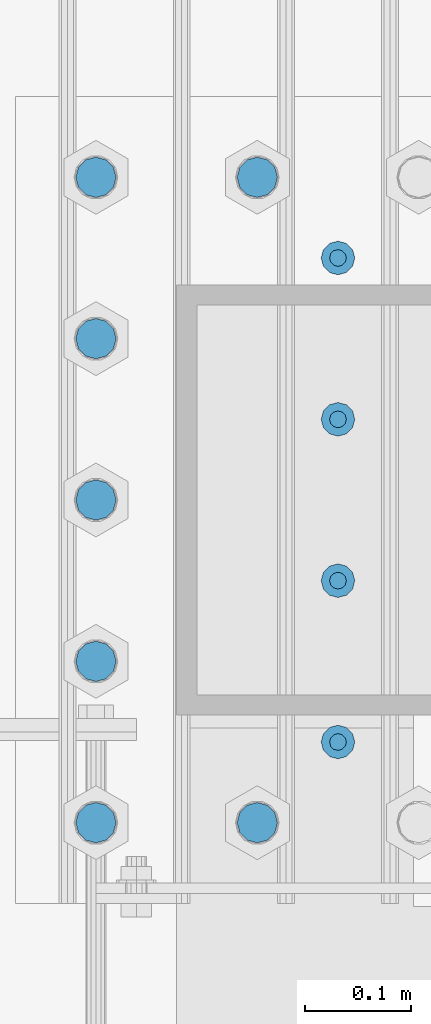
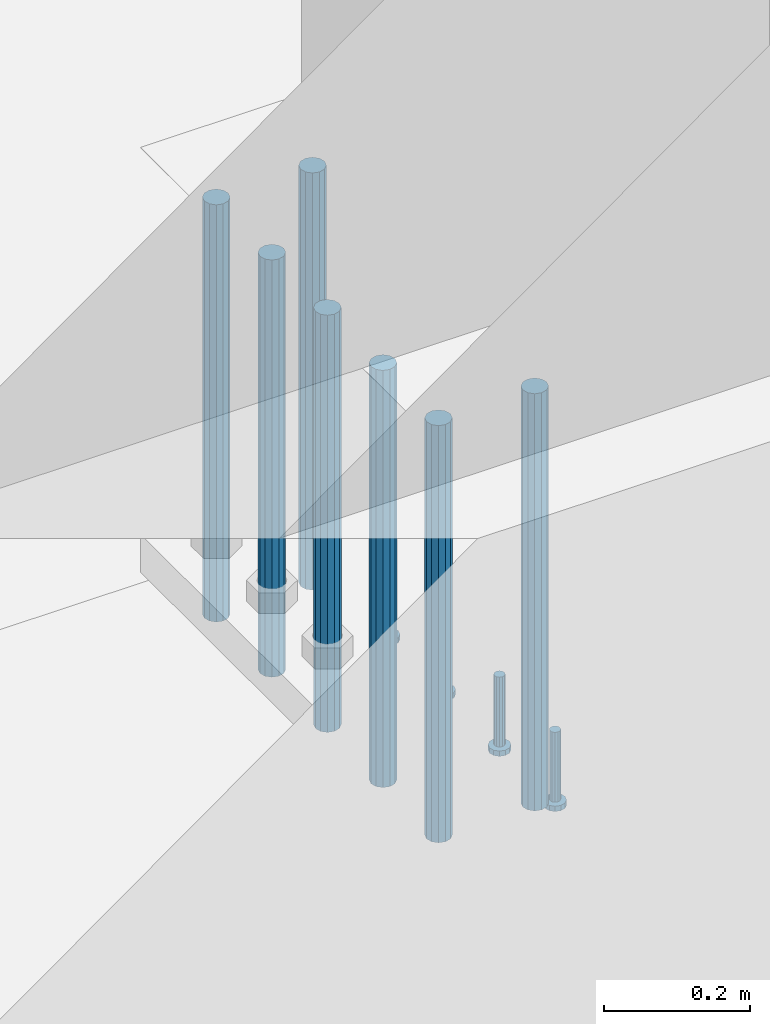
# One storey, part 1088 of 1876: 11 beams, 1 element without a shape of its own.
"""IFC2X3 building model written with IfcOpenShell, lengths in millimetres."""

from ifc_helpers import new_model, si_unit, frame, origin_with_axes, place, context, subcontext, project, spatial, faceted_brep, material, type_object, element, aggregate, save


model = new_model("IFC2X3")

# Units and contexts
model_context = context("Model", 3, precision=1e-05, world=origin_with_axes())
body_context = subcontext(model_context, "Body", "Model", "MODEL_VIEW")
ifc_project = project(units=[si_unit("LENGTHUNIT", "METRE", prefix="MILLI"), si_unit("AREAUNIT", "SQUARE_METRE"), si_unit("VOLUMEUNIT", "CUBIC_METRE"), si_unit("MASSUNIT", "GRAM", prefix="KILO"), si_unit("TIMEUNIT", "SECOND"), si_unit("PLANEANGLEUNIT", "RADIAN"), si_unit("SOLIDANGLEUNIT", "STERADIAN"), si_unit("THERMODYNAMICTEMPERATUREUNIT", "DEGREE_CELSIUS"), si_unit("LUMINOUSINTENSITYUNIT", "LUMEN")], contexts=[model_context])

# Site, building, storey
site_placement = place(None, origin_with_axes())
site = spatial("IfcSite", under=ifc_project, at=site_placement, CompositionType="ELEMENT")
building_placement = place(site_placement, origin_with_axes())
building = spatial("IfcBuilding", under=site, at=building_placement, Name="Undefined", CompositionType="ELEMENT")
storey_placement = place(building_placement, origin_with_axes())
storey = spatial("IfcBuildingStorey", under=building, at=storey_placement, Name="Undefined", CompositionType="ELEMENT", Elevation=0.0)

# Assembly, beams
assembly_placement = place(storey_placement, origin_with_axes())
assembly = element("IfcElementAssembly", 1, at=assembly_placement, inside=storey, Name="PLATE", AssemblyPlace="NOTDEFINED", PredefinedType="RIGID_FRAME")
ifc_material_1 = material(Name="STEEL/F1554-55, S1")
beam_type_1 = type_object("IfcBeamType", PredefinedType="NOTDEFINED")
beam_1_placement = place(assembly_placement, frame((7318.37500610347, -25552.4000091553, -63.4999999999993), z_axis=(-1.0, 0.0, 0.0), x_axis=(0.0, 0.0, -1.0)))
beam_1 = element("IfcBeam", 2, at=beam_1_placement, type_object=beam_type_1, material=ifc_material_1, Name="WELDED ANCHORS", context=body_context, shape_type="Brep", body=[
    faceted_brep([(0.0, -19.0500000000002, 0.0), (0.0, -16.4977839420935, -9.52500000000146), (698.499999999999, -16.4977839420935, -9.52499999999964), (698.499999999999, -19.0499999999993, 0.0), (0.0, -9.52500000000009, -16.4977839420935), (698.499999999999, -9.52500000000146, -16.4977839420935), (0.0, 0.0, -19.05), (698.499999999999, 0.0, -19.0500000000002), (0.0, 9.52500000000009, -16.4977839420935), (698.499999999999, 9.52500000000146, -16.4977839420935), (0.0, 16.4977839420935, -9.52500000000146), (698.499999999999, 16.4977839420935, -9.52499999999964), (-9.09494701772928e-13, 19.05, -1.81898940354586e-12), (698.499999999999, 19.0499999999993, 0.0), (0.0, 16.4977839420935, 9.52500000000146), (698.499999999999, 16.4977839420935, 9.52499999999964), (0.0, 9.52500000000009, 16.4977839420935), (698.499999999999, 9.52500000000146, 16.4977839420935), (0.0, 0.0, 19.0499999999993), (698.499999999999, 0.0, 19.0500000000002), (0.0, -9.52500000000009, 16.4977839420935), (698.499999999999, -9.52500000000146, 16.4977839420935), (0.0, -16.4977839420935, 9.52500000000146), (698.499999999999, -16.4977839420935, 9.52499999999964)], [[[0, 1, 2, 3]], [[1, 4, 5, 2]], [[4, 6, 7, 5]], [[6, 8, 9, 7]], [[8, 10, 11, 9]], [[10, 12, 13, 11]], [[12, 14, 15, 13]], [[14, 16, 17, 15]], [[16, 18, 19, 17]], [[18, 20, 21, 19]], [[20, 22, 23, 21]], [[22, 0, 3, 23]], [[5, 7, 9, 11, 13, 15, 17, 19, 21, 23, 3, 2]], [[22, 20, 18, 16, 14, 12, 10, 8, 6, 4, 1, 0]]]),
])
beam_2_placement = place(assembly_placement, frame((7318.37502441406, -25399.999987793, -63.4999999999993), z_axis=(-1.0, 0.0, 0.0), x_axis=(0.0, 0.0, -1.0)))
beam_2 = element("IfcBeam", 3, at=beam_2_placement, type_object=beam_type_1, material=ifc_material_1, Name="WELDED ANCHORS", context=body_context, shape_type="Brep", body=[
    faceted_brep([(0.0, -19.0500000000002, 0.0), (0.0, -16.4977839420935, -9.52500000000146), (698.499999999999, -16.4977839420935, -9.52499999999964), (698.499999999999, -19.0499999999993, 0.0), (0.0, -9.52500000000009, -16.4977839420935), (698.499999999999, -9.52500000000146, -16.4977839420935), (0.0, 0.0, -19.05), (698.499999999999, 0.0, -19.0500000000002), (0.0, 9.52500000000009, -16.4977839420935), (698.499999999999, 9.52500000000146, -16.4977839420935), (0.0, 16.4977839420935, -9.52500000000146), (698.499999999999, 16.4977839420935, -9.52499999999964), (-9.09494701772928e-13, 19.05, -1.81898940354586e-12), (698.499999999999, 19.0499999999993, 0.0), (0.0, 16.4977839420935, 9.52500000000146), (698.499999999999, 16.4977839420935, 9.52499999999964), (0.0, 9.52500000000009, 16.4977839420935), (698.499999999999, 9.52500000000146, 16.4977839420935), (0.0, 0.0, 19.0499999999993), (698.499999999999, 0.0, 19.0500000000002), (0.0, -9.52500000000009, 16.4977839420935), (698.499999999999, -9.52500000000146, 16.4977839420935), (0.0, -16.4977839420935, 9.52500000000146), (698.499999999999, -16.4977839420935, 9.52499999999964)], [[[0, 1, 2, 3]], [[1, 4, 5, 2]], [[4, 6, 7, 5]], [[6, 8, 9, 7]], [[8, 10, 11, 9]], [[10, 12, 13, 11]], [[12, 14, 15, 13]], [[14, 16, 17, 15]], [[16, 18, 19, 17]], [[18, 20, 21, 19]], [[20, 22, 23, 21]], [[22, 0, 3, 23]], [[5, 7, 9, 11, 13, 15, 17, 19, 21, 23, 3, 2]], [[22, 20, 18, 16, 14, 12, 10, 8, 6, 4, 1, 0]]]),
])
beam_3_placement = place(assembly_placement, frame((7318.37500610347, -25247.5999908447, -63.4999999999993), z_axis=(-1.0, 0.0, 0.0), x_axis=(0.0, 0.0, -1.0)))
beam_3 = element("IfcBeam", 4, at=beam_3_placement, type_object=beam_type_1, material=ifc_material_1, Name="WELDED ANCHORS", context=body_context, shape_type="Brep", body=[
    faceted_brep([(0.0, -19.0500000000002, 0.0), (0.0, -16.4977839420935, -9.52500000000146), (698.499999999999, -16.4977839420935, -9.52499999999964), (698.499999999999, -19.0499999999993, 0.0), (0.0, -9.52500000000009, -16.4977839420935), (698.499999999999, -9.52500000000146, -16.4977839420935), (0.0, 0.0, -19.05), (698.499999999999, 0.0, -19.0500000000002), (0.0, 9.52500000000009, -16.4977839420935), (698.499999999999, 9.52500000000146, -16.4977839420935), (0.0, 16.4977839420935, -9.52500000000146), (698.499999999999, 16.4977839420935, -9.52499999999964), (-9.09494701772928e-13, 19.05, -1.81898940354586e-12), (698.499999999999, 19.0499999999993, 0.0), (0.0, 16.4977839420935, 9.52500000000146), (698.499999999999, 16.4977839420935, 9.52499999999964), (0.0, 9.52500000000009, 16.4977839420935), (698.499999999999, 9.52500000000146, 16.4977839420935), (0.0, 0.0, 19.0499999999993), (698.499999999999, 0.0, 19.0500000000002), (0.0, -9.52500000000009, 16.4977839420935), (698.499999999999, -9.52500000000146, 16.4977839420935), (0.0, -16.4977839420935, 9.52500000000146), (698.499999999999, -16.4977839420935, 9.52499999999964)], [[[0, 1, 2, 3]], [[1, 4, 5, 2]], [[4, 6, 7, 5]], [[6, 8, 9, 7]], [[8, 10, 11, 9]], [[10, 12, 13, 11]], [[12, 14, 15, 13]], [[14, 16, 17, 15]], [[16, 18, 19, 17]], [[18, 20, 21, 19]], [[20, 22, 23, 21]], [[22, 0, 3, 23]], [[5, 7, 9, 11, 13, 15, 17, 19, 21, 23, 3, 2]], [[22, 20, 18, 16, 14, 12, 10, 8, 6, 4, 1, 0]]]),
])
beam_4_placement = place(assembly_placement, frame((7470.77501627604, -25095.199987793, -63.4999999999993), z_axis=(-1.0, 0.0, 0.0), x_axis=(0.0, 0.0, -1.0)))
beam_4 = element("IfcBeam", 5, at=beam_4_placement, type_object=beam_type_1, material=ifc_material_1, Name="WELDED ANCHORS", context=body_context, shape_type="Brep", body=[
    faceted_brep([(0.0, -19.0500000000002, 0.0), (0.0, -16.4977839420935, -9.52500000000146), (698.499999999999, -16.4977839420935, -9.52499999999964), (698.499999999999, -19.0499999999993, 0.0), (0.0, -9.52500000000009, -16.4977839420935), (698.499999999999, -9.52500000000146, -16.4977839420935), (0.0, 0.0, -19.05), (698.499999999999, 0.0, -19.0500000000002), (0.0, 9.52500000000009, -16.4977839420935), (698.499999999999, 9.52500000000146, -16.4977839420935), (0.0, 16.4977839420935, -9.52500000000146), (698.499999999999, 16.4977839420935, -9.52499999999964), (-9.09494701772928e-13, 19.05, -1.81898940354586e-12), (698.499999999999, 19.0499999999993, 0.0), (0.0, 16.4977839420935, 9.52500000000146), (698.499999999999, 16.4977839420935, 9.52499999999964), (0.0, 9.52500000000009, 16.4977839420935), (698.499999999999, 9.52500000000146, 16.4977839420935), (0.0, 0.0, 19.0499999999993), (698.499999999999, 0.0, 19.0500000000002), (0.0, -9.52500000000009, 16.4977839420935), (698.499999999999, -9.52500000000146, 16.4977839420935), (0.0, -16.4977839420935, 9.52500000000146), (698.499999999999, -16.4977839420935, 9.52499999999964)], [[[0, 1, 2, 3]], [[1, 4, 5, 2]], [[4, 6, 7, 5]], [[6, 8, 9, 7]], [[8, 10, 11, 9]], [[10, 12, 13, 11]], [[12, 14, 15, 13]], [[14, 16, 17, 15]], [[16, 18, 19, 17]], [[18, 20, 21, 19]], [[20, 22, 23, 21]], [[22, 0, 3, 23]], [[5, 7, 9, 11, 13, 15, 17, 19, 21, 23, 3, 2]], [[22, 20, 18, 16, 14, 12, 10, 8, 6, 4, 1, 0]]]),
])
beam_5_placement = place(assembly_placement, frame((7318.37502441406, -25095.199987793, -63.4999999999993), z_axis=(-1.0, 0.0, 0.0), x_axis=(0.0, 0.0, -1.0)))
beam_5 = element("IfcBeam", 6, at=beam_5_placement, type_object=beam_type_1, material=ifc_material_1, Name="WELDED ANCHORS", context=body_context, shape_type="Brep", body=[
    faceted_brep([(0.0, -19.0500000000002, 0.0), (0.0, -16.4977839420935, -9.52500000000146), (698.499999999999, -16.4977839420935, -9.52499999999964), (698.499999999999, -19.0499999999993, 0.0), (0.0, -9.52500000000009, -16.4977839420935), (698.499999999999, -9.52500000000146, -16.4977839420935), (0.0, 0.0, -19.05), (698.499999999999, 0.0, -19.0500000000002), (0.0, 9.52500000000009, -16.4977839420935), (698.499999999999, 9.52500000000146, -16.4977839420935), (0.0, 16.4977839420935, -9.52500000000146), (698.499999999999, 16.4977839420935, -9.52499999999964), (-9.09494701772928e-13, 19.05, -1.81898940354586e-12), (698.499999999999, 19.0499999999993, 0.0), (0.0, 16.4977839420935, 9.52500000000146), (698.499999999999, 16.4977839420935, 9.52499999999964), (0.0, 9.52500000000009, 16.4977839420935), (698.499999999999, 9.52500000000146, 16.4977839420935), (0.0, 0.0, 19.0499999999993), (698.499999999999, 0.0, 19.0500000000002), (0.0, -9.52500000000009, 16.4977839420935), (698.499999999999, -9.52500000000146, 16.4977839420935), (0.0, -16.4977839420935, 9.52500000000146), (698.499999999999, -16.4977839420935, 9.52499999999964)], [[[0, 1, 2, 3]], [[1, 4, 5, 2]], [[4, 6, 7, 5]], [[6, 8, 9, 7]], [[8, 10, 11, 9]], [[10, 12, 13, 11]], [[12, 14, 15, 13]], [[14, 16, 17, 15]], [[16, 18, 19, 17]], [[18, 20, 21, 19]], [[20, 22, 23, 21]], [[22, 0, 3, 23]], [[5, 7, 9, 11, 13, 15, 17, 19, 21, 23, 3, 2]], [[22, 20, 18, 16, 14, 12, 10, 8, 6, 4, 1, 0]]]),
])
beam_6_placement = place(assembly_placement, frame((7470.77501627604, -25704.8, -63.4999999999993), z_axis=(-1.0, 0.0, 0.0), x_axis=(0.0, 0.0, -1.0)))
beam_6 = element("IfcBeam", 7, at=beam_6_placement, type_object=beam_type_1, material=ifc_material_1, Name="WELDED ANCHORS", context=body_context, shape_type="Brep", body=[
    faceted_brep([(0.0, -19.0500000000002, 0.0), (0.0, -16.4977839420935, -9.52500000000146), (698.499999999999, -16.4977839420935, -9.52499999999964), (698.499999999999, -19.0499999999993, 0.0), (0.0, -9.52500000000009, -16.4977839420935), (698.499999999999, -9.52500000000146, -16.4977839420935), (0.0, 0.0, -19.05), (698.499999999999, 0.0, -19.0500000000002), (0.0, 9.52500000000009, -16.4977839420935), (698.499999999999, 9.52500000000146, -16.4977839420935), (0.0, 16.4977839420935, -9.52500000000146), (698.499999999999, 16.4977839420935, -9.52499999999964), (-9.09494701772928e-13, 19.05, -1.81898940354586e-12), (698.499999999999, 19.0499999999993, 0.0), (0.0, 16.4977839420935, 9.52500000000146), (698.499999999999, 16.4977839420935, 9.52499999999964), (0.0, 9.52500000000009, 16.4977839420935), (698.499999999999, 9.52500000000146, 16.4977839420935), (0.0, 0.0, 19.0499999999993), (698.499999999999, 0.0, 19.0500000000002), (0.0, -9.52500000000009, 16.4977839420935), (698.499999999999, -9.52500000000146, 16.4977839420935), (0.0, -16.4977839420935, 9.52500000000146), (698.499999999999, -16.4977839420935, 9.52499999999964)], [[[0, 1, 2, 3]], [[1, 4, 5, 2]], [[4, 6, 7, 5]], [[6, 8, 9, 7]], [[8, 10, 11, 9]], [[10, 12, 13, 11]], [[12, 14, 15, 13]], [[14, 16, 17, 15]], [[16, 18, 19, 17]], [[18, 20, 21, 19]], [[20, 22, 23, 21]], [[22, 0, 3, 23]], [[5, 7, 9, 11, 13, 15, 17, 19, 21, 23, 3, 2]], [[22, 20, 18, 16, 14, 12, 10, 8, 6, 4, 1, 0]]]),
])
beam_7_placement = place(assembly_placement, frame((7318.37502441406, -25704.8, -63.4999999999993), z_axis=(-1.0, 0.0, 0.0), x_axis=(0.0, 0.0, -1.0)))
beam_7 = element("IfcBeam", 8, at=beam_7_placement, type_object=beam_type_1, material=ifc_material_1, Name="WELDED ANCHORS", context=body_context, shape_type="Brep", body=[
    faceted_brep([(0.0, -19.0500000000002, 0.0), (0.0, -16.4977839420935, -9.52500000000146), (698.499999999999, -16.4977839420935, -9.52499999999964), (698.499999999999, -19.0499999999993, 0.0), (0.0, -9.52500000000009, -16.4977839420935), (698.499999999999, -9.52500000000146, -16.4977839420935), (0.0, 0.0, -19.05), (698.499999999999, 0.0, -19.0500000000002), (0.0, 9.52500000000009, -16.4977839420935), (698.499999999999, 9.52500000000146, -16.4977839420935), (0.0, 16.4977839420935, -9.52500000000146), (698.499999999999, 16.4977839420935, -9.52499999999964), (-9.09494701772928e-13, 19.05, -1.81898940354586e-12), (698.499999999999, 19.0499999999993, 0.0), (0.0, 16.4977839420935, 9.52500000000146), (698.499999999999, 16.4977839420935, 9.52499999999964), (0.0, 9.52500000000009, 16.4977839420935), (698.499999999999, 9.52500000000146, 16.4977839420935), (0.0, 0.0, 19.0499999999993), (698.499999999999, 0.0, 19.0500000000002), (0.0, -9.52500000000009, 16.4977839420935), (698.499999999999, -9.52500000000146, 16.4977839420935), (0.0, -16.4977839420935, 9.52500000000146), (698.499999999999, -16.4977839420935, 9.52499999999964)], [[[0, 1, 2, 3]], [[1, 4, 5, 2]], [[4, 6, 7, 5]], [[6, 8, 9, 7]], [[8, 10, 11, 9]], [[10, 12, 13, 11]], [[12, 14, 15, 13]], [[14, 16, 17, 15]], [[16, 18, 19, 17]], [[18, 20, 21, 19]], [[20, 22, 23, 21]], [[22, 0, 3, 23]], [[5, 7, 9, 11, 13, 15, 17, 19, 21, 23, 3, 2]], [[22, 20, 18, 16, 14, 12, 10, 8, 6, 4, 1, 0]]]),
])
ifc_material_2 = material(Name="STEEL/A108")
beam_type_2 = type_object("IfcBeamType", Name="5/8-DIA_HEADED ANCHOR STUD", PredefinedType="NOTDEFINED")
beam_8_placement = place(assembly_placement, frame((7546.97501220698, -25628.6000061035, -711.199999999997), z_axis=(0.0, -1.0, 0.0), x_axis=(0.0, 0.0, -1.0)))
beam_8 = element("IfcBeam", 9, at=beam_8_placement, type_object=beam_type_2, material=ifc_material_2, Name="HEADED ANCHOR STUD", ObjectType="5/8-DIA_HEADED ANCHOR STUD", context=body_context, shape_type="Brep", body=[
    faceted_brep([(0.0, -7.94000005722046, 0.0), (0.0, -6.86999988555908, -3.97000002861023), (116.84, -6.86999988555908, -3.97000002861023), (116.84, -7.94000005722046, 0.0), (0.0, -3.97000002861023, -6.86999988555908), (116.84, -3.97000002861023, -6.86999988555908), (0.0, 0.0, -7.94000005722046), (116.84, 0.0, -7.94000005722046), (0.0, 3.97000002861023, -6.86999988555908), (116.84, 3.97000002861023, -6.86999988555908), (0.0, 6.86999988555908, -3.97000002861023), (116.84, 6.86999988555908, -3.97000002861023), (0.0, 7.94000005722046, 0.0), (116.84, 7.94000005722046, 0.0), (0.0, 6.86999988555908, 3.97000002861023), (116.84, 6.86999988555908, 3.97000002861023), (0.0, 3.97000002861023, 6.86999988555908), (116.84, 3.97000002861023, 6.86999988555908), (0.0, 0.0, 7.94000005722046), (116.84, 0.0, 7.94000005722046), (0.0, -3.97000002861023, 6.86999988555908), (116.84, -3.97000002861023, 6.86999988555908), (0.0, -6.86999988555908, 3.97000002861023), (116.84, -6.86999988555908, 3.97000002861023), (118.11, -13.75, -7.94000005722046), (118.11, -15.8800001144409, 0.0), (118.11, -7.94000005722046, -13.75), (118.11, 0.0, -15.8800001144409), (118.11, 7.94000005722046, -13.75), (118.11, 13.75, -7.94000005722046), (118.11, 15.8800001144409, 0.0), (118.11, 13.75, 7.94000005722046), (118.11, 7.94000005722046, 13.75), (118.11, 0.0, 15.8800001144409), (118.11, -7.94000005722046, 13.75), (118.11, -13.75, 7.94000005722046), (127.0, -13.75, -7.94000005722046), (127.0, -15.8800001144409, 0.0), (127.0, -7.94000005722046, -13.75), (127.0, 0.0, -15.8800001144409), (127.0, 7.94000005722046, -13.75), (127.0, 13.75, -7.94000005722046), (127.0, 15.8800001144409, 0.0), (127.0, 13.75, 7.94000005722046), (127.0, 7.94000005722046, 13.75), (127.0, 0.0, 15.8800001144409), (127.0, -7.94000005722046, 13.75), (127.0, -13.75, 7.94000005722046)], [[[0, 1, 2, 3]], [[1, 4, 5, 2]], [[4, 6, 7, 5]], [[6, 8, 9, 7]], [[8, 10, 11, 9]], [[10, 12, 13, 11]], [[12, 14, 15, 13]], [[14, 16, 17, 15]], [[16, 18, 19, 17]], [[18, 20, 21, 19]], [[20, 22, 23, 21]], [[22, 0, 3, 23]], [[22, 20, 18, 16, 14, 12, 10, 8, 6, 4, 1, 0]], [[3, 2, 24, 25]], [[2, 5, 26, 24]], [[5, 7, 27, 26]], [[7, 9, 28, 27]], [[9, 11, 29, 28]], [[11, 13, 30, 29]], [[13, 15, 31, 30]], [[15, 17, 32, 31]], [[17, 19, 33, 32]], [[19, 21, 34, 33]], [[21, 23, 35, 34]], [[23, 3, 25, 35]], [[25, 24, 36, 37]], [[24, 26, 38, 36]], [[26, 27, 39, 38]], [[27, 28, 40, 39]], [[28, 29, 41, 40]], [[29, 30, 42, 41]], [[30, 31, 43, 42]], [[31, 32, 44, 43]], [[32, 33, 45, 44]], [[33, 34, 46, 45]], [[34, 35, 47, 46]], [[35, 25, 37, 47]], [[38, 39, 40, 41, 42, 43, 44, 45, 46, 47, 37, 36]]]),
])
beam_9_placement = place(assembly_placement, frame((7546.975, -25476.200012207, -711.199999999997), z_axis=(0.0, -1.0, 0.0), x_axis=(0.0, 0.0, -1.0)))
beam_9 = element("IfcBeam", 10, at=beam_9_placement, type_object=beam_type_2, material=ifc_material_2, Name="HEADED ANCHOR STUD", ObjectType="5/8-DIA_HEADED ANCHOR STUD", context=body_context, shape_type="Brep", body=[
    faceted_brep([(0.0, -7.94000005722046, 0.0), (0.0, -6.86999988555908, -3.97000002861023), (116.84, -6.86999988555908, -3.97000002861023), (116.84, -7.94000005722046, 0.0), (0.0, -3.97000002861023, -6.86999988555908), (116.84, -3.97000002861023, -6.86999988555908), (0.0, 0.0, -7.94000005722046), (116.84, 0.0, -7.94000005722046), (0.0, 3.97000002861023, -6.86999988555908), (116.84, 3.97000002861023, -6.86999988555908), (0.0, 6.86999988555908, -3.97000002861023), (116.84, 6.86999988555908, -3.97000002861023), (0.0, 7.94000005722046, 0.0), (116.84, 7.94000005722046, 0.0), (0.0, 6.86999988555908, 3.97000002861023), (116.84, 6.86999988555908, 3.97000002861023), (0.0, 3.97000002861023, 6.86999988555908), (116.84, 3.97000002861023, 6.86999988555908), (0.0, 0.0, 7.94000005722046), (116.84, 0.0, 7.94000005722046), (0.0, -3.97000002861023, 6.86999988555908), (116.84, -3.97000002861023, 6.86999988555908), (0.0, -6.86999988555908, 3.97000002861023), (116.84, -6.86999988555908, 3.97000002861023), (118.11, -13.75, -7.94000005722046), (118.11, -15.8800001144409, 0.0), (118.11, -7.94000005722046, -13.75), (118.11, 0.0, -15.8800001144409), (118.11, 7.94000005722046, -13.75), (118.11, 13.75, -7.94000005722046), (118.11, 15.8800001144409, 0.0), (118.11, 13.75, 7.94000005722046), (118.11, 7.94000005722046, 13.75), (118.11, 0.0, 15.8800001144409), (118.11, -7.94000005722046, 13.75), (118.11, -13.75, 7.94000005722046), (127.0, -13.75, -7.94000005722046), (127.0, -15.8800001144409, 0.0), (127.0, -7.94000005722046, -13.75), (127.0, 0.0, -15.8800001144409), (127.0, 7.94000005722046, -13.75), (127.0, 13.75, -7.94000005722046), (127.0, 15.8800001144409, 0.0), (127.0, 13.75, 7.94000005722046), (127.0, 7.94000005722046, 13.75), (127.0, 0.0, 15.8800001144409), (127.0, -7.94000005722046, 13.75), (127.0, -13.75, 7.94000005722046)], [[[0, 1, 2, 3]], [[1, 4, 5, 2]], [[4, 6, 7, 5]], [[6, 8, 9, 7]], [[8, 10, 11, 9]], [[10, 12, 13, 11]], [[12, 14, 15, 13]], [[14, 16, 17, 15]], [[16, 18, 19, 17]], [[18, 20, 21, 19]], [[20, 22, 23, 21]], [[22, 0, 3, 23]], [[22, 20, 18, 16, 14, 12, 10, 8, 6, 4, 1, 0]], [[3, 2, 24, 25]], [[2, 5, 26, 24]], [[5, 7, 27, 26]], [[7, 9, 28, 27]], [[9, 11, 29, 28]], [[11, 13, 30, 29]], [[13, 15, 31, 30]], [[15, 17, 32, 31]], [[17, 19, 33, 32]], [[19, 21, 34, 33]], [[21, 23, 35, 34]], [[23, 3, 25, 35]], [[25, 24, 36, 37]], [[24, 26, 38, 36]], [[26, 27, 39, 38]], [[27, 28, 40, 39]], [[28, 29, 41, 40]], [[29, 30, 42, 41]], [[30, 31, 43, 42]], [[31, 32, 44, 43]], [[32, 33, 45, 44]], [[33, 34, 46, 45]], [[34, 35, 47, 46]], [[35, 25, 37, 47]], [[38, 39, 40, 41, 42, 43, 44, 45, 46, 47, 37, 36]]]),
])
beam_10_placement = place(assembly_placement, frame((7546.975, -25323.8000152588, -711.199999999997), z_axis=(0.0, -1.0, 0.0), x_axis=(0.0, 0.0, -1.0)))
beam_10 = element("IfcBeam", 11, at=beam_10_placement, type_object=beam_type_2, material=ifc_material_2, Name="HEADED ANCHOR STUD", ObjectType="5/8-DIA_HEADED ANCHOR STUD", context=body_context, shape_type="Brep", body=[
    faceted_brep([(0.0, -7.94000005722046, 0.0), (0.0, -6.86999988555908, -3.97000002861023), (116.84, -6.86999988555908, -3.97000002861023), (116.84, -7.94000005722046, 0.0), (0.0, -3.97000002861023, -6.86999988555908), (116.84, -3.97000002861023, -6.86999988555908), (0.0, 0.0, -7.94000005722046), (116.84, 0.0, -7.94000005722046), (0.0, 3.97000002861023, -6.86999988555908), (116.84, 3.97000002861023, -6.86999988555908), (0.0, 6.86999988555908, -3.97000002861023), (116.84, 6.86999988555908, -3.97000002861023), (0.0, 7.94000005722046, 0.0), (116.84, 7.94000005722046, 0.0), (0.0, 6.86999988555908, 3.97000002861023), (116.84, 6.86999988555908, 3.97000002861023), (0.0, 3.97000002861023, 6.86999988555908), (116.84, 3.97000002861023, 6.86999988555908), (0.0, 0.0, 7.94000005722046), (116.84, 0.0, 7.94000005722046), (0.0, -3.97000002861023, 6.86999988555908), (116.84, -3.97000002861023, 6.86999988555908), (0.0, -6.86999988555908, 3.97000002861023), (116.84, -6.86999988555908, 3.97000002861023), (118.11, -13.75, -7.94000005722046), (118.11, -15.8800001144409, 0.0), (118.11, -7.94000005722046, -13.75), (118.11, 0.0, -15.8800001144409), (118.11, 7.94000005722046, -13.75), (118.11, 13.75, -7.94000005722046), (118.11, 15.8800001144409, 0.0), (118.11, 13.75, 7.94000005722046), (118.11, 7.94000005722046, 13.75), (118.11, 0.0, 15.8800001144409), (118.11, -7.94000005722046, 13.75), (118.11, -13.75, 7.94000005722046), (127.0, -13.75, -7.94000005722046), (127.0, -15.8800001144409, 0.0), (127.0, -7.94000005722046, -13.75), (127.0, 0.0, -15.8800001144409), (127.0, 7.94000005722046, -13.75), (127.0, 13.75, -7.94000005722046), (127.0, 15.8800001144409, 0.0), (127.0, 13.75, 7.94000005722046), (127.0, 7.94000005722046, 13.75), (127.0, 0.0, 15.8800001144409), (127.0, -7.94000005722046, 13.75), (127.0, -13.75, 7.94000005722046)], [[[0, 1, 2, 3]], [[1, 4, 5, 2]], [[4, 6, 7, 5]], [[6, 8, 9, 7]], [[8, 10, 11, 9]], [[10, 12, 13, 11]], [[12, 14, 15, 13]], [[14, 16, 17, 15]], [[16, 18, 19, 17]], [[18, 20, 21, 19]], [[20, 22, 23, 21]], [[22, 0, 3, 23]], [[22, 20, 18, 16, 14, 12, 10, 8, 6, 4, 1, 0]], [[3, 2, 24, 25]], [[2, 5, 26, 24]], [[5, 7, 27, 26]], [[7, 9, 28, 27]], [[9, 11, 29, 28]], [[11, 13, 30, 29]], [[13, 15, 31, 30]], [[15, 17, 32, 31]], [[17, 19, 33, 32]], [[19, 21, 34, 33]], [[21, 23, 35, 34]], [[23, 3, 25, 35]], [[25, 24, 36, 37]], [[24, 26, 38, 36]], [[26, 27, 39, 38]], [[27, 28, 40, 39]], [[28, 29, 41, 40]], [[29, 30, 42, 41]], [[30, 31, 43, 42]], [[31, 32, 44, 43]], [[32, 33, 45, 44]], [[33, 34, 46, 45]], [[34, 35, 47, 46]], [[35, 25, 37, 47]], [[38, 39, 40, 41, 42, 43, 44, 45, 46, 47, 37, 36]]]),
])
beam_11_placement = place(assembly_placement, frame((7546.97501220698, -25171.4000091553, -711.199999999997), z_axis=(0.0, -1.0, 0.0), x_axis=(0.0, 0.0, -1.0)))
beam_11 = element("IfcBeam", 12, at=beam_11_placement, type_object=beam_type_2, material=ifc_material_2, Name="HEADED ANCHOR STUD", ObjectType="5/8-DIA_HEADED ANCHOR STUD", context=body_context, shape_type="Brep", body=[
    faceted_brep([(0.0, -7.94000005722046, 0.0), (0.0, -6.86999988555908, -3.97000002861023), (116.84, -6.86999988555908, -3.97000002861023), (116.84, -7.94000005722046, 0.0), (0.0, -3.97000002861023, -6.86999988555908), (116.84, -3.97000002861023, -6.86999988555908), (0.0, 0.0, -7.94000005722046), (116.84, 0.0, -7.94000005722046), (0.0, 3.97000002861023, -6.86999988555908), (116.84, 3.97000002861023, -6.86999988555908), (0.0, 6.86999988555908, -3.97000002861023), (116.84, 6.86999988555908, -3.97000002861023), (0.0, 7.94000005722046, 0.0), (116.84, 7.94000005722046, 0.0), (0.0, 6.86999988555908, 3.97000002861023), (116.84, 6.86999988555908, 3.97000002861023), (0.0, 3.97000002861023, 6.86999988555908), (116.84, 3.97000002861023, 6.86999988555908), (0.0, 0.0, 7.94000005722046), (116.84, 0.0, 7.94000005722046), (0.0, -3.97000002861023, 6.86999988555908), (116.84, -3.97000002861023, 6.86999988555908), (0.0, -6.86999988555908, 3.97000002861023), (116.84, -6.86999988555908, 3.97000002861023), (118.11, -13.75, -7.94000005722046), (118.11, -15.8800001144409, 0.0), (118.11, -7.94000005722046, -13.75), (118.11, 0.0, -15.8800001144409), (118.11, 7.94000005722046, -13.75), (118.11, 13.75, -7.94000005722046), (118.11, 15.8800001144409, 0.0), (118.11, 13.75, 7.94000005722046), (118.11, 7.94000005722046, 13.75), (118.11, 0.0, 15.8800001144409), (118.11, -7.94000005722046, 13.75), (118.11, -13.75, 7.94000005722046), (127.0, -13.75, -7.94000005722046), (127.0, -15.8800001144409, 0.0), (127.0, -7.94000005722046, -13.75), (127.0, 0.0, -15.8800001144409), (127.0, 7.94000005722046, -13.75), (127.0, 13.75, -7.94000005722046), (127.0, 15.8800001144409, 0.0), (127.0, 13.75, 7.94000005722046), (127.0, 7.94000005722046, 13.75), (127.0, 0.0, 15.8800001144409), (127.0, -7.94000005722046, 13.75), (127.0, -13.75, 7.94000005722046)], [[[0, 1, 2, 3]], [[1, 4, 5, 2]], [[4, 6, 7, 5]], [[6, 8, 9, 7]], [[8, 10, 11, 9]], [[10, 12, 13, 11]], [[12, 14, 15, 13]], [[14, 16, 17, 15]], [[16, 18, 19, 17]], [[18, 20, 21, 19]], [[20, 22, 23, 21]], [[22, 0, 3, 23]], [[22, 20, 18, 16, 14, 12, 10, 8, 6, 4, 1, 0]], [[3, 2, 24, 25]], [[2, 5, 26, 24]], [[5, 7, 27, 26]], [[7, 9, 28, 27]], [[9, 11, 29, 28]], [[11, 13, 30, 29]], [[13, 15, 31, 30]], [[15, 17, 32, 31]], [[17, 19, 33, 32]], [[19, 21, 34, 33]], [[21, 23, 35, 34]], [[23, 3, 25, 35]], [[25, 24, 36, 37]], [[24, 26, 38, 36]], [[26, 27, 39, 38]], [[27, 28, 40, 39]], [[28, 29, 41, 40]], [[29, 30, 42, 41]], [[30, 31, 43, 42]], [[31, 32, 44, 43]], [[32, 33, 45, 44]], [[33, 34, 46, 45]], [[34, 35, 47, 46]], [[35, 25, 37, 47]], [[38, 39, 40, 41, 42, 43, 44, 45, 46, 47, 37, 36]]]),
])
aggregate(assembly, [beam_8, beam_9, beam_10, beam_11, beam_1, beam_2, beam_3, beam_4, beam_5, beam_6, beam_7])

save(model, "model.ifc")
